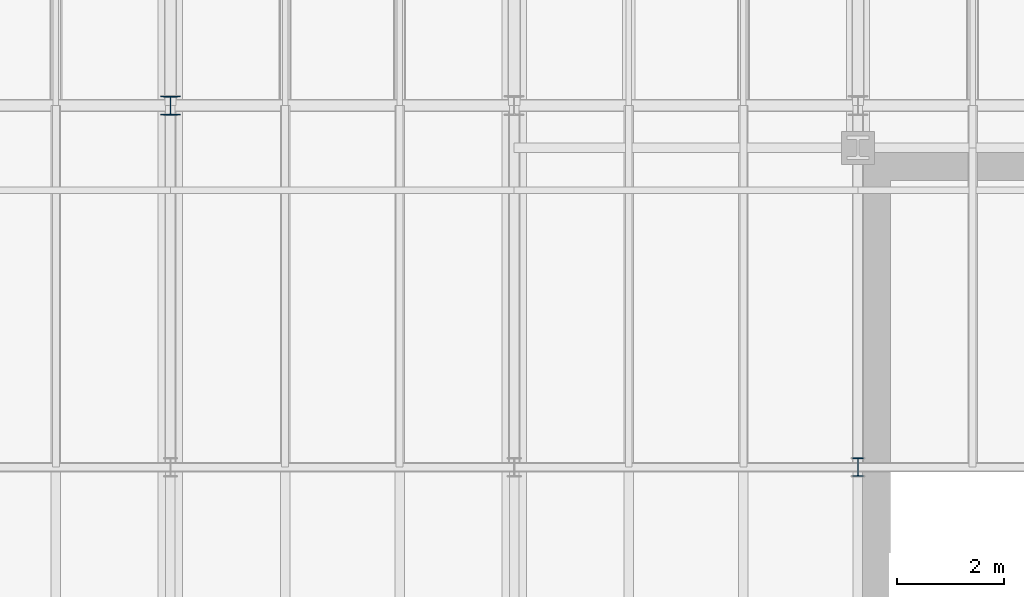
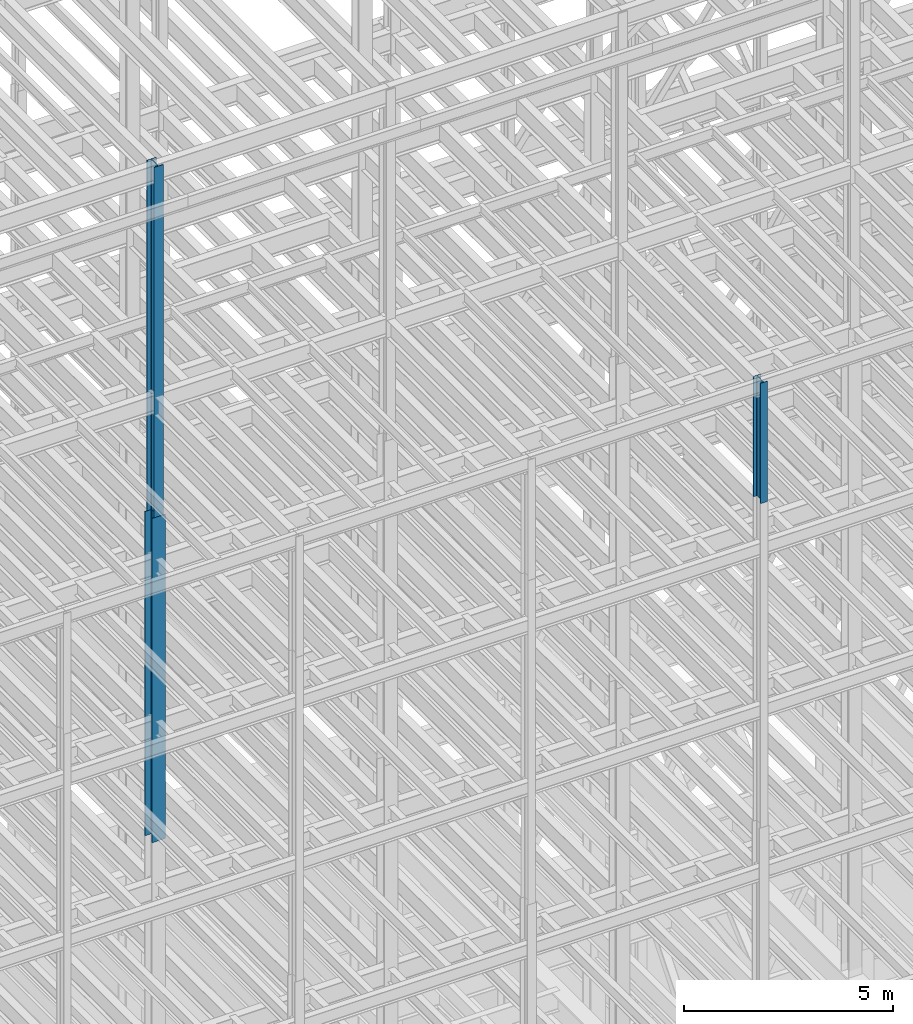
# One storey, part 25 of 150: 3 columns.
"""IFC2X3 building model written with IfcOpenShell, lengths in millimetres."""

from ifc_helpers import new_model, si_unit, frame, origin_with_axes, origin_2d_with_axis, place, context, subcontext, project, spatial, i_section, extrude, material, type_object, element, save


model = new_model("IFC2X3")

# Units and contexts
model_context = context("Model", 3, precision=1e-05, world=origin_with_axes())
body_context = subcontext(model_context, "Body", "Model", "MODEL_VIEW")
ifc_project = project(units=[si_unit("LENGTHUNIT", "METRE", prefix="MILLI"), si_unit("AREAUNIT", "SQUARE_METRE"), si_unit("VOLUMEUNIT", "CUBIC_METRE"), si_unit("MASSUNIT", "GRAM", prefix="KILO"), si_unit("TIMEUNIT", "SECOND"), si_unit("PLANEANGLEUNIT", "RADIAN"), si_unit("SOLIDANGLEUNIT", "STERADIAN"), si_unit("THERMODYNAMICTEMPERATUREUNIT", "DEGREE_CELSIUS"), si_unit("LUMINOUSINTENSITYUNIT", "LUMEN")], contexts=[model_context])

# Site, building, storey
site_placement = place(None, origin_with_axes())
site = spatial("IfcSite", under=ifc_project, at=site_placement, CompositionType="ELEMENT")
building_placement = place(site_placement, origin_with_axes())
building = spatial("IfcBuilding", under=site, at=building_placement, Name="Undefined", CompositionType="ELEMENT")
storey_placement = place(building_placement, origin_with_axes())
storey = spatial("IfcBuildingStorey", under=building, at=storey_placement, Name="Undefined", CompositionType="ELEMENT", Elevation=0.0)

# Columns
ifc_material = material(Name="STEEL/A992")
column_type_1 = type_object("IfcColumnType", Name="W14X43", PredefinedType="NOTDEFINED")
column_1_placement = place(storey_placement, frame((43789.6, 3454.40000000001, 55702.2), z_axis=(0.0, 0.0, 1.0), x_axis=(1.0, 0.0, 0.0)))
element("IfcColumn", 1, at=column_1_placement, inside=storey, type_object=column_type_1, material=ifc_material, Name="COLUMN", ObjectType="W14X43", context=body_context, shape_type="SweptSolid", body=[
    extrude(i_section(OverallWidth=203.2, OverallDepth=346.075, WebThickness=7.9375, FlangeThickness=13.462, FilletRadius=21.4629, at=origin_2d_with_axis()), frame((0.0, 0.0, 3505.20000000001), z_axis=(0.0, 0.0, -1.0), x_axis=(-1.0, 0.0, 0.0)), (0.0, 0.0, 1.0), 3505.20000000001),
])
column_type_2 = type_object("IfcColumnType", Name="W14X61", PredefinedType="NOTDEFINED")
column_2_placement = place(storey_placement, frame((30988.0, 10185.4, 55702.2), z_axis=(0.0, 0.0, 1.0), x_axis=(1.0, 0.0, 0.0)))
element("IfcColumn", 2, at=column_2_placement, inside=storey, type_object=column_type_2, material=ifc_material, Name="COLUMN", ObjectType="W14X61", context=body_context, shape_type="SweptSolid", body=[
    extrude(i_section(OverallWidth=254.0, OverallDepth=352.425, WebThickness=9.5249, FlangeThickness=16.383, FilletRadius=21.717, at=origin_2d_with_axis()), frame((0.0, 0.0, 10210.8), z_axis=(0.0, 0.0, -1.0), x_axis=(-1.0, 0.0, 0.0)), (0.0, 0.0, 1.0), 10210.8),
])
column_type_3 = type_object("IfcColumnType", Name="W14X90", PredefinedType="NOTDEFINED")
column_3_placement = place(storey_placement, frame((30988.0, 10185.4, 46253.4), z_axis=(0.0, 0.0, 1.0), x_axis=(1.0, 0.0, 0.0)))
element("IfcColumn", 3, at=column_3_placement, inside=storey, type_object=column_type_3, material=ifc_material, Name="COLUMN", ObjectType="W14X90", context=body_context, shape_type="SweptSolid", body=[
    extrude(i_section(OverallWidth=368.3, OverallDepth=355.6, WebThickness=11.1125, FlangeThickness=18.034, FilletRadius=32.7659, at=origin_2d_with_axis()), frame((0.0, 0.0, 9448.8), z_axis=(0.0, 0.0, -1.0), x_axis=(-1.0, 0.0, 0.0)), (0.0, 0.0, 1.0), 9448.8),
])

save(model, "model.ifc")
